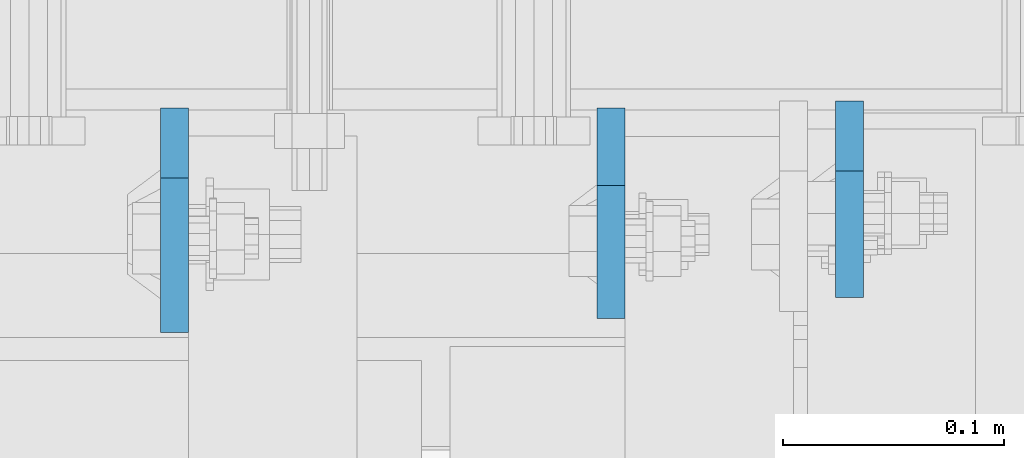
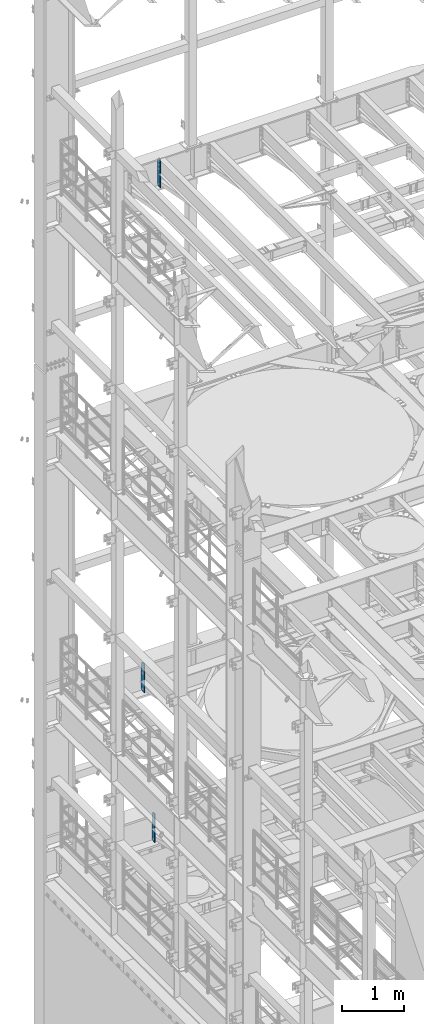
# One storey, part 1781 of 1876: 3 plates, 3 elements without a shape of their own.
"""IFC2X3 building model written with IfcOpenShell, lengths in millimetres."""

from ifc_helpers import new_model, si_unit, frame, origin_with_axes, place, context, subcontext, project, spatial, faceted_brep, material, type_object, element, aggregate, save


model = new_model("IFC2X3")

# Units and contexts
model_context = context("Model", 3, precision=1e-05, world=origin_with_axes())
body_context = subcontext(model_context, "Body", "Model", "MODEL_VIEW")
ifc_project = project(units=[si_unit("LENGTHUNIT", "METRE", prefix="MILLI"), si_unit("AREAUNIT", "SQUARE_METRE"), si_unit("VOLUMEUNIT", "CUBIC_METRE"), si_unit("MASSUNIT", "GRAM", prefix="KILO"), si_unit("TIMEUNIT", "SECOND"), si_unit("PLANEANGLEUNIT", "RADIAN"), si_unit("SOLIDANGLEUNIT", "STERADIAN"), si_unit("THERMODYNAMICTEMPERATUREUNIT", "DEGREE_CELSIUS"), si_unit("LUMINOUSINTENSITYUNIT", "LUMEN")], contexts=[model_context])

# Site, building, storey
site_placement = place(None, origin_with_axes())
site = spatial("IfcSite", under=ifc_project, at=site_placement, CompositionType="ELEMENT")
building_placement = place(site_placement, origin_with_axes())
building = spatial("IfcBuilding", under=site, at=building_placement, Name="Undefined", CompositionType="ELEMENT")
storey_placement = place(building_placement, origin_with_axes())
storey = spatial("IfcBuildingStorey", under=building, at=storey_placement, Name="Undefined", CompositionType="ELEMENT", Elevation=0.0)

# Assembly, plate
assembly_1_placement = place(storey_placement, origin_with_axes())
assembly_1 = element("IfcElementAssembly", 1, at=assembly_1_placement, inside=storey, Name="BEAM", AssemblyPlace="NOTDEFINED", PredefinedType="RIGID_FRAME")
ifc_material = material(Name="STEEL/A36")
plate_type_1 = type_object("IfcPlateType", PredefinedType="NOTDEFINED")
plate_1_placement = place(assembly_1_placement, frame((1920.87499990463, 13708.85625, 17386.3), z_axis=(0.0, 0.0, 1.0), x_axis=(0.0, -1.0, 0.0)))
plate_1 = element("IfcPlate", 2, at=plate_1_placement, type_object=plate_type_1, material=ifc_material, Name="PLATE", context=body_context, shape_type="Brep", body=[
    faceted_brep([(0.0, -6.34999999999991, 31.75), (0.0, -6.34999999999991, 539.75), (0.0, 6.34999999999991, 539.75), (0.0, 6.34999999999991, 31.75), (31.75, -6.34999999999991, 571.5), (31.75, 6.34999999999991, 571.5), (88.9000015258789, -6.34999999999991, 571.5), (88.9000015258789, 6.34999999999991, 571.5), (88.9000015258789, -6.34999999999991, 0.0), (88.9000015258789, 6.34999999999991, 0.0), (31.75, -6.34999999999991, 0.0), (31.75, 6.34999999999991, 0.0)], [[[0, 1, 2, 3]], [[1, 4, 5, 2]], [[4, 6, 7, 5]], [[6, 8, 9, 7]], [[8, 10, 11, 9]], [[10, 0, 3, 11]], [[5, 7, 9, 11, 3, 2]], [[10, 8, 6, 4, 1, 0]]]),
])
aggregate(assembly_1, [plate_1])

assembly_2_placement = place(storey_placement, origin_with_axes())
assembly_2 = element("IfcElementAssembly", 3, at=assembly_2_placement, inside=storey, Name="BEAM", AssemblyPlace="NOTDEFINED", PredefinedType="RIGID_FRAME")
plate_type_2 = type_object("IfcPlateType", PredefinedType="NOTDEFINED")
plate_2_placement = place(assembly_2_placement, frame((1812.92499990463, 13705.68125, 4521.2), z_axis=(0.0, 0.0, 1.0), x_axis=(0.0, -1.0, 0.0)))
plate_2 = element("IfcPlate", 4, at=plate_2_placement, type_object=plate_type_2, material=ifc_material, Name="PLATE", context=body_context, shape_type="Brep", body=[
    faceted_brep([(0.0, -6.34999999999991, 34.9249992370605), (0.0, -6.35000000000036, 538.162475585938), (0.0, 6.35000000000036, 538.162475585938), (0.0, 6.34999999999991, 34.9249992370605), (34.9249992370605, -6.34999999999991, 573.087524414062), (34.9249992370605, 6.34999999999991, 573.087524414062), (95.25, -6.34999999999991, 573.087524414062), (95.25, 6.34999999999991, 573.087524414062), (95.25, -6.35000000000036, 0.0), (95.25, 6.35000000000036, 0.0), (34.9249992370605, -6.34999999999991, 0.0), (34.9249992370605, 6.34999999999991, 0.0)], [[[0, 1, 2, 3]], [[1, 4, 5, 2]], [[4, 6, 7, 5]], [[6, 8, 9, 7]], [[8, 10, 11, 9]], [[10, 0, 3, 11]], [[5, 7, 9, 11, 3, 2]], [[10, 8, 6, 4, 1, 0]]]),
])
aggregate(assembly_2, [plate_2])

assembly_3_placement = place(storey_placement, origin_with_axes())
assembly_3 = element("IfcElementAssembly", 5, at=assembly_3_placement, inside=storey, Name="BEAM", AssemblyPlace="NOTDEFINED", PredefinedType="RIGID_FRAME")
plate_type_3 = type_object("IfcPlateType", PredefinedType="NOTDEFINED")
plate_3_placement = place(assembly_3_placement, frame((1615.28124990463, 13705.68125, 7543.8), z_axis=(0.0, 0.0, 1.0), x_axis=(0.0, -1.0, 0.0)))
plate_3 = element("IfcPlate", 6, at=plate_3_placement, type_object=plate_type_3, material=ifc_material, Name="PLATE", context=body_context, shape_type="Brep", body=[
    faceted_brep([(0.0, -6.34999999999991, 31.75), (0.0, -6.35000000000036, 541.337524414062), (0.0, 6.35000000000036, 541.337524414062), (0.0, 6.34999999999991, 31.75), (31.75, -6.35000000000036, 573.087524414062), (31.75, 6.35000000000036, 573.087524414062), (101.599998474121, -6.35000000000036, 573.087524414062), (101.599998474121, 6.35000000000036, 573.087524414062), (101.599998474121, -6.35000000000036, 0.0), (101.599998474121, 6.35000000000036, 0.0), (31.75, -6.34999999999991, 0.0), (31.75, 6.34999999999991, 0.0)], [[[0, 1, 2, 3]], [[1, 4, 5, 2]], [[4, 6, 7, 5]], [[6, 8, 9, 7]], [[8, 10, 11, 9]], [[10, 0, 3, 11]], [[5, 7, 9, 11, 3, 2]], [[10, 8, 6, 4, 1, 0]]]),
])
aggregate(assembly_3, [plate_3])

save(model, "model.ifc")
